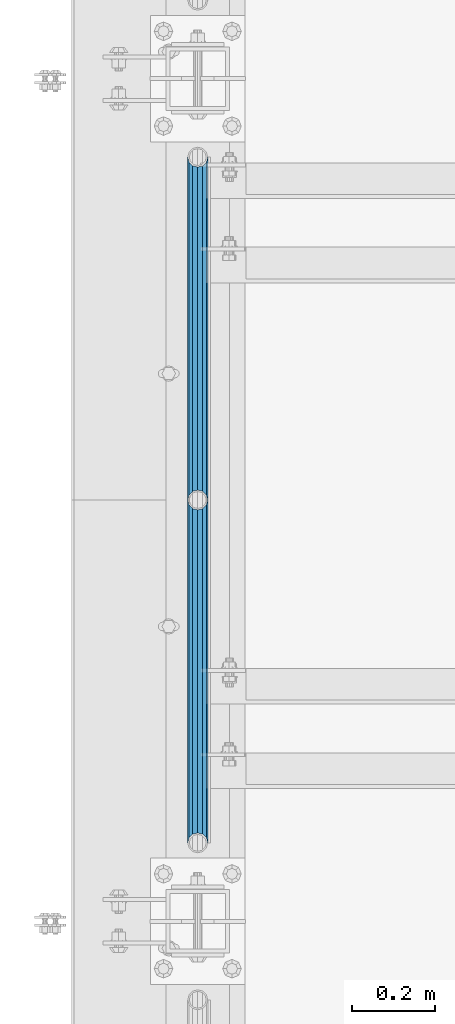
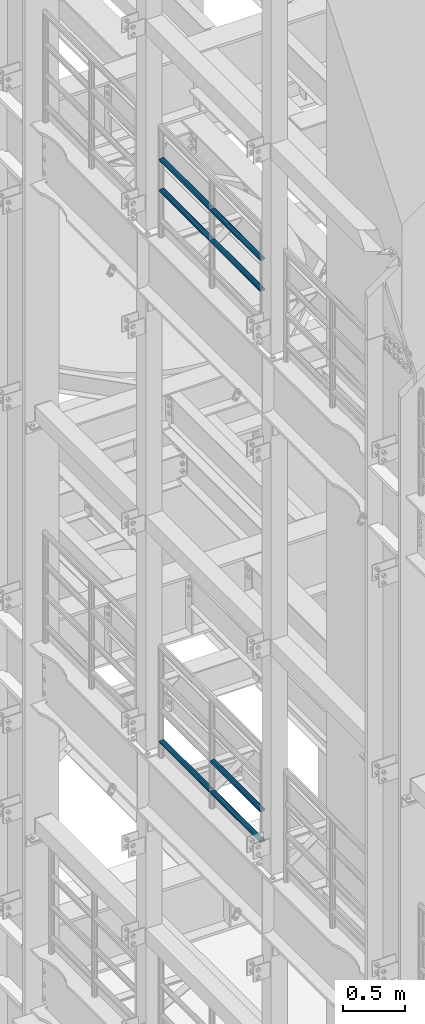
# One storey, part 1252 of 1876: 7 beams, 2 elements without a shape of their own.
"""IFC2X3 building model written with IfcOpenShell, lengths in millimetres."""

from ifc_helpers import new_model, si_unit, frame, origin_with_axes, place, context, subcontext, project, spatial, faceted_brep, material, type_object, element, aggregate, save


model = new_model("IFC2X3")

# Units and contexts
model_context = context("Model", 3, precision=1e-05, world=origin_with_axes())
body_context = subcontext(model_context, "Body", "Model", "MODEL_VIEW")
ifc_project = project(units=[si_unit("LENGTHUNIT", "METRE", prefix="MILLI"), si_unit("AREAUNIT", "SQUARE_METRE"), si_unit("VOLUMEUNIT", "CUBIC_METRE"), si_unit("MASSUNIT", "GRAM", prefix="KILO"), si_unit("TIMEUNIT", "SECOND"), si_unit("PLANEANGLEUNIT", "RADIAN"), si_unit("SOLIDANGLEUNIT", "STERADIAN"), si_unit("THERMODYNAMICTEMPERATUREUNIT", "DEGREE_CELSIUS"), si_unit("LUMINOUSINTENSITYUNIT", "LUMEN")], contexts=[model_context])

# Site, building, storey
site_placement = place(None, origin_with_axes())
site = spatial("IfcSite", under=ifc_project, at=site_placement, CompositionType="ELEMENT")
building_placement = place(site_placement, origin_with_axes())
building = spatial("IfcBuilding", under=site, at=building_placement, Name="Undefined", CompositionType="ELEMENT")
storey_placement = place(building_placement, origin_with_axes())
storey = spatial("IfcBuildingStorey", under=building, at=storey_placement, Name="Undefined", CompositionType="ELEMENT", Elevation=0.0)

# Assembly, beams
assembly_1_placement = place(storey_placement, origin_with_axes())
assembly_1 = element("IfcElementAssembly", 1, at=assembly_1_placement, inside=storey, Name="RAIL", AssemblyPlace="NOTDEFINED", PredefinedType="RIGID_FRAME")
ifc_material = material()
beam_type = type_object("IfcBeamType", Name="PIPE1-1/2SCH40", PredefinedType="NOTDEFINED")
beam_1_placement = place(assembly_1_placement, frame((-1.81898940354586e-12, 3745.23, 13776.325), z_axis=(0.0, 0.0, -1.0), x_axis=(0.0, 1.0, 0.0)))
beam_1 = element("IfcBeam", 2, at=beam_1_placement, type_object=beam_type, material=ifc_material, Name="RAIL", ObjectType="PIPE1-1/2SCH40", context=body_context, shape_type="Brep", body=[
    faceted_brep([(0.0, 24.1299999999992, 0.0), (12.0650000000064, 20.8971929933177, -12.0649999999987), (12.0650000000064, 20.8971929933177, 12.0649999999987), (12.0650000000064, -20.8971929933177, 12.0649999999987), (12.0650000000064, -20.8971929933177, -12.0649999999987), (0.0, -24.1299999999992, 0.0), (20.8971929933249, -12.0650000000005, 20.8971929933177), (20.8971929933249, -12.0650000000005, 15.8661214311796), (15.2545715621445, -17.7076214311801, 10.2235000000001), (12.5151929933249, -20.4470000000001, 0.0), (15.2545715621445, -17.7076214311801, -10.2235000000001), (20.8971929933249, -12.0650000000005, -15.8661214311796), (20.8971929933249, -12.0650000000005, -20.8971929933177), (24.1300000000063, 0.0, -20.4470000000001), (24.1300000000063, 0.0, -24.130000000001), (21.3906214311868, -10.2235000000001, -17.7076214311819), (21.3906214311868, 10.2235000000001, -17.7076214311819), (20.8971929933249, 12.0650000000005, -15.8661214311796), (20.8971929933249, 12.0650000000005, -20.8971929933177), (15.2545715621445, 17.7076214311801, -10.2235000000001), (12.5151929933249, 20.4470000000001, 0.0), (15.2545715621445, 17.7076214311801, 10.2235000000001), (20.8971929933249, 12.0650000000005, 15.8661214311796), (20.8971929933249, 12.0650000000005, 20.8971929933177), (21.3906214311868, 10.2235000000001, 17.7076214311819), (24.1300000000064, 0.0, 20.4470000000001), (24.1300000000064, 0.0, 24.130000000001), (21.3906214311868, -10.2235000000001, 17.7076214311819), (826.77, 24.1300000000001, 0.0), (814.705, 20.8971929933186, -12.0649999999987), (805.872807006681, 12.0649999999996, -20.8971929933177), (826.77, -24.1300000000001, 0.0), (814.705, -20.8971929933186, -12.0649999999987), (814.705, -20.8971929933186, 12.0649999999987), (805.872807006681, -12.0649999999996, 20.8971929933177), (805.872807006681, -12.0649999999996, -20.8971929933177), (802.640000000001, 0.0, -24.130000000001), (805.379378568819, 10.2235000000001, -17.7076214311819), (802.640000000001, 0.0, -20.4470000000001), (805.872807006683, 12.0649999999996, -15.8661214311796), (805.872807006683, -12.0649999999996, -15.8661214311796), (805.379378568819, -10.2235000000001, -17.7076214311819), (811.515428437862, -17.7076214311801, -10.2235000000001), (814.254807006682, -20.4470000000001, 0.0), (811.515428437862, -17.7076214311801, 10.2235000000001), (805.872807006683, -12.0649999999996, 15.8661214311796), (805.379378568819, -10.2235000000001, 17.7076214311819), (802.640000000001, 0.0, 20.4470000000001), (802.640000000001, 0.0, 24.130000000001), (805.872807006681, 12.0649999999996, 20.8971929933177), (814.705, 20.8971929933186, 12.0649999999987), (805.872807006683, 12.0649999999996, 15.8661214311796), (811.515428437862, 17.7076214311801, 10.2235000000001), (814.254807006682, 20.4470000000001, 0.0), (811.515428437862, 17.7076214311801, -10.2235000000001), (805.379378568819, 10.2235000000001, 17.7076214311819)], [[[0, 1, 2]], [[3, 4, 5]], [[6, 7, 8, 9, 10, 11, 12, 4, 3]], [[13, 14, 12, 11, 15]], [[16, 17, 18, 14, 13]], [[2, 1, 18, 17, 19, 20, 21, 22, 23]], [[23, 22, 24, 25, 26]], [[26, 25, 27, 7, 6]], [[1, 0, 28, 29]], [[18, 1, 29, 30]], [[31, 32, 33]], [[6, 3, 33, 34]], [[3, 5, 31, 33]], [[5, 4, 32, 31]], [[4, 12, 35, 32]], [[12, 14, 36, 35]], [[14, 18, 30, 36]], [[37, 38, 36, 30, 39]], [[40, 35, 36, 38, 41]], [[33, 32, 35, 40, 42, 43, 44, 45, 34]], [[34, 45, 46, 47, 48]], [[26, 6, 34, 48]], [[2, 23, 49, 50]], [[23, 26, 48, 49]], [[0, 2, 50, 28]], [[28, 50, 29]], [[49, 51, 52, 53, 54, 39, 30, 29, 50]], [[48, 47, 55, 51, 49]], [[25, 24, 55, 47]], [[55, 24, 22, 21, 52, 51]], [[21, 20, 53, 52]], [[20, 19, 54, 53]], [[19, 17, 16, 37, 39, 54]], [[16, 13, 38, 37]], [[13, 15, 41, 38]], [[41, 15, 11, 10, 42, 40]], [[10, 9, 43, 42]], [[9, 8, 44, 43]], [[8, 7, 27, 46, 45, 44]], [[27, 25, 47, 46]]]),
])
beam_2_placement = place(assembly_1_placement, frame((-1.81898940354586e-12, 4572.0, 13776.325), z_axis=(0.0, 0.0, -1.0), x_axis=(0.0, 1.0, 0.0)))
beam_2 = element("IfcBeam", 3, at=beam_2_placement, type_object=beam_type, material=ifc_material, Name="RAIL", ObjectType="PIPE1-1/2SCH40", context=body_context, shape_type="Brep", body=[
    faceted_brep([(0.0, 24.1299999999992, 0.0), (12.0650000000064, 20.8971929933177, -12.0649999999987), (12.0650000000064, 20.8971929933177, 12.0649999999987), (12.0650000000064, -20.8971929933177, 12.0649999999987), (12.0650000000064, -20.8971929933177, -12.0649999999987), (0.0, -24.1299999999992, 0.0), (20.8971929933249, -12.0650000000005, 20.8971929933177), (20.8971929933249, -12.0650000000005, 15.8661214311796), (15.2545715621445, -17.7076214311801, 10.2235000000001), (12.5151929933249, -20.4470000000001, 0.0), (15.2545715621445, -17.7076214311801, -10.2235000000001), (20.8971929933249, -12.0650000000005, -15.8661214311796), (20.8971929933249, -12.0650000000005, -20.8971929933177), (24.1300000000063, 0.0, -20.4470000000001), (24.1300000000063, 0.0, -24.130000000001), (21.3906214311868, -10.2235000000001, -17.7076214311819), (21.3906214311868, 10.2235000000001, -17.7076214311819), (20.8971929933249, 12.0650000000005, -15.8661214311796), (20.8971929933249, 12.0650000000005, -20.8971929933177), (15.2545715621445, 17.7076214311801, -10.2235000000001), (12.5151929933249, 20.4470000000001, 0.0), (15.2545715621445, 17.7076214311801, 10.2235000000001), (20.8971929933249, 12.0650000000005, 15.8661214311796), (20.8971929933249, 12.0650000000005, 20.8971929933177), (21.3906214311868, 10.2235000000001, 17.7076214311819), (24.1300000000064, 0.0, 20.4470000000001), (24.1300000000064, 0.0, 24.130000000001), (21.3906214311868, -10.2235000000001, 17.7076214311819), (826.77, 24.1300000000001, 0.0), (814.705, 20.8971929933186, -12.0649999999987), (805.872807006681, 12.0649999999996, -20.8971929933177), (826.77, -24.1300000000001, 0.0), (814.705, -20.8971929933186, -12.0649999999987), (814.705, -20.8971929933186, 12.0649999999987), (805.872807006681, -12.0649999999996, 20.8971929933177), (805.872807006681, -12.0649999999996, -20.8971929933177), (802.640000000001, 0.0, -24.130000000001), (805.379378568819, 10.2235000000001, -17.7076214311819), (802.640000000001, 0.0, -20.4470000000001), (805.872807006683, 12.0649999999996, -15.8661214311796), (805.872807006683, -12.0649999999996, -15.8661214311796), (805.379378568819, -10.2235000000001, -17.7076214311819), (811.515428437862, -17.7076214311801, -10.2235000000001), (814.254807006682, -20.4470000000001, 0.0), (811.515428437862, -17.7076214311801, 10.2235000000001), (805.872807006683, -12.0649999999996, 15.8661214311796), (805.379378568819, -10.2235000000001, 17.7076214311819), (802.640000000001, 0.0, 20.4470000000001), (802.640000000001, 0.0, 24.130000000001), (805.872807006681, 12.0649999999996, 20.8971929933177), (814.705, 20.8971929933186, 12.0649999999987), (805.872807006683, 12.0649999999996, 15.8661214311796), (811.515428437862, 17.7076214311801, 10.2235000000001), (814.254807006682, 20.4470000000001, 0.0), (811.515428437862, 17.7076214311801, -10.2235000000001), (805.379378568819, 10.2235000000001, 17.7076214311819)], [[[0, 1, 2]], [[3, 4, 5]], [[6, 7, 8, 9, 10, 11, 12, 4, 3]], [[13, 14, 12, 11, 15]], [[16, 17, 18, 14, 13]], [[2, 1, 18, 17, 19, 20, 21, 22, 23]], [[23, 22, 24, 25, 26]], [[26, 25, 27, 7, 6]], [[1, 0, 28, 29]], [[18, 1, 29, 30]], [[31, 32, 33]], [[6, 3, 33, 34]], [[3, 5, 31, 33]], [[5, 4, 32, 31]], [[4, 12, 35, 32]], [[12, 14, 36, 35]], [[14, 18, 30, 36]], [[37, 38, 36, 30, 39]], [[40, 35, 36, 38, 41]], [[33, 32, 35, 40, 42, 43, 44, 45, 34]], [[34, 45, 46, 47, 48]], [[26, 6, 34, 48]], [[2, 23, 49, 50]], [[23, 26, 48, 49]], [[0, 2, 50, 28]], [[28, 50, 29]], [[49, 51, 52, 53, 54, 39, 30, 29, 50]], [[48, 47, 55, 51, 49]], [[25, 24, 55, 47]], [[55, 24, 22, 21, 52, 51]], [[21, 20, 53, 52]], [[20, 19, 54, 53]], [[19, 17, 16, 37, 39, 54]], [[16, 13, 38, 37]], [[13, 15, 41, 38]], [[41, 15, 11, 10, 42, 40]], [[10, 9, 43, 42]], [[9, 8, 44, 43]], [[8, 7, 27, 46, 45, 44]], [[27, 25, 47, 46]]]),
])
beam_3_placement = place(assembly_1_placement, frame((-1.81898940354586e-12, 3745.23, 14081.125), z_axis=(0.0, 0.0, -1.0), x_axis=(0.0, 1.0, 0.0)))
beam_3 = element("IfcBeam", 4, at=beam_3_placement, type_object=beam_type, material=ifc_material, Name="RAIL", ObjectType="PIPE1-1/2SCH40", context=body_context, shape_type="Brep", body=[
    faceted_brep([(0.0, 24.1299999999992, 0.0), (12.0650000000064, 20.8971929933177, -12.0649999999987), (12.0650000000064, 20.8971929933177, 12.0649999999987), (12.0650000000064, -20.8971929933177, 12.0649999999987), (12.0650000000064, -20.8971929933177, -12.0649999999987), (0.0, -24.1299999999992, 0.0), (20.8971929933249, -12.0650000000005, 20.8971929933177), (20.8971929933249, -12.0650000000005, 15.8661214311796), (15.2545715621445, -17.7076214311801, 10.2235000000001), (12.5151929933249, -20.4470000000001, 0.0), (15.2545715621445, -17.7076214311801, -10.2235000000001), (20.8971929933249, -12.0650000000005, -15.8661214311796), (20.8971929933249, -12.0650000000005, -20.8971929933177), (24.1300000000063, 0.0, -20.4470000000001), (24.1300000000063, 0.0, -24.130000000001), (21.3906214311868, -10.2235000000001, -17.7076214311819), (21.3906214311868, 10.2235000000001, -17.7076214311819), (20.8971929933249, 12.0650000000005, -15.8661214311796), (20.8971929933249, 12.0650000000005, -20.8971929933177), (15.2545715621445, 17.7076214311801, -10.2235000000001), (12.5151929933249, 20.4470000000001, 0.0), (15.2545715621445, 17.7076214311801, 10.2235000000001), (20.8971929933249, 12.0650000000005, 15.8661214311796), (20.8971929933249, 12.0650000000005, 20.8971929933177), (21.3906214311868, 10.2235000000001, 17.7076214311819), (24.1300000000064, 0.0, 20.4470000000001), (24.1300000000064, 0.0, 24.130000000001), (21.3906214311868, -10.2235000000001, 17.7076214311819), (826.77, 24.1300000000001, 0.0), (814.705, 20.8971929933186, -12.0649999999987), (805.872807006681, 12.0649999999996, -20.8971929933177), (826.77, -24.1300000000001, 0.0), (814.705, -20.8971929933186, -12.0649999999987), (814.705, -20.8971929933186, 12.0649999999987), (805.872807006681, -12.0649999999996, 20.8971929933177), (805.872807006681, -12.0649999999996, -20.8971929933177), (802.640000000001, 0.0, -24.130000000001), (805.379378568819, 10.2235000000001, -17.7076214311819), (802.640000000001, 0.0, -20.4470000000001), (805.872807006683, 12.0649999999996, -15.8661214311796), (805.872807006683, -12.0649999999996, -15.8661214311796), (805.379378568819, -10.2235000000001, -17.7076214311819), (811.515428437862, -17.7076214311801, -10.2235000000001), (814.254807006682, -20.4470000000001, 0.0), (811.515428437862, -17.7076214311801, 10.2235000000001), (805.872807006683, -12.0649999999996, 15.8661214311796), (805.379378568819, -10.2235000000001, 17.7076214311819), (802.640000000001, 0.0, 20.4470000000001), (802.640000000001, 0.0, 24.130000000001), (805.872807006681, 12.0649999999996, 20.8971929933177), (814.705, 20.8971929933186, 12.0649999999987), (805.872807006683, 12.0649999999996, 15.8661214311796), (811.515428437862, 17.7076214311801, 10.2235000000001), (814.254807006682, 20.4470000000001, 0.0), (811.515428437862, 17.7076214311801, -10.2235000000001), (805.379378568819, 10.2235000000001, 17.7076214311819)], [[[0, 1, 2]], [[3, 4, 5]], [[6, 7, 8, 9, 10, 11, 12, 4, 3]], [[13, 14, 12, 11, 15]], [[16, 17, 18, 14, 13]], [[2, 1, 18, 17, 19, 20, 21, 22, 23]], [[23, 22, 24, 25, 26]], [[26, 25, 27, 7, 6]], [[1, 0, 28, 29]], [[18, 1, 29, 30]], [[31, 32, 33]], [[6, 3, 33, 34]], [[3, 5, 31, 33]], [[5, 4, 32, 31]], [[4, 12, 35, 32]], [[12, 14, 36, 35]], [[14, 18, 30, 36]], [[37, 38, 36, 30, 39]], [[40, 35, 36, 38, 41]], [[33, 32, 35, 40, 42, 43, 44, 45, 34]], [[34, 45, 46, 47, 48]], [[26, 6, 34, 48]], [[2, 23, 49, 50]], [[23, 26, 48, 49]], [[0, 2, 50, 28]], [[28, 50, 29]], [[49, 51, 52, 53, 54, 39, 30, 29, 50]], [[48, 47, 55, 51, 49]], [[25, 24, 55, 47]], [[55, 24, 22, 21, 52, 51]], [[21, 20, 53, 52]], [[20, 19, 54, 53]], [[19, 17, 16, 37, 39, 54]], [[16, 13, 38, 37]], [[13, 15, 41, 38]], [[41, 15, 11, 10, 42, 40]], [[10, 9, 43, 42]], [[9, 8, 44, 43]], [[8, 7, 27, 46, 45, 44]], [[27, 25, 47, 46]]]),
])
beam_4_placement = place(assembly_1_placement, frame((-1.81898940354586e-12, 4572.0, 14081.125), z_axis=(0.0, 0.0, -1.0), x_axis=(0.0, 1.0, 0.0)))
beam_4 = element("IfcBeam", 5, at=beam_4_placement, type_object=beam_type, material=ifc_material, Name="RAIL", ObjectType="PIPE1-1/2SCH40", context=body_context, shape_type="Brep", body=[
    faceted_brep([(0.0, 24.1299999999992, 0.0), (12.0650000000064, 20.8971929933177, -12.0649999999987), (12.0650000000064, 20.8971929933177, 12.0649999999987), (12.0650000000064, -20.8971929933177, 12.0649999999987), (12.0650000000064, -20.8971929933177, -12.0649999999987), (0.0, -24.1299999999992, 0.0), (20.8971929933249, -12.0650000000005, 20.8971929933177), (20.8971929933249, -12.0650000000005, 15.8661214311796), (15.2545715621445, -17.7076214311801, 10.2235000000001), (12.5151929933249, -20.4470000000001, 0.0), (15.2545715621445, -17.7076214311801, -10.2235000000001), (20.8971929933249, -12.0650000000005, -15.8661214311796), (20.8971929933249, -12.0650000000005, -20.8971929933177), (24.1300000000063, 0.0, -20.4470000000001), (24.1300000000063, 0.0, -24.130000000001), (21.3906214311868, -10.2235000000001, -17.7076214311819), (21.3906214311868, 10.2235000000001, -17.7076214311819), (20.8971929933249, 12.0650000000005, -15.8661214311796), (20.8971929933249, 12.0650000000005, -20.8971929933177), (15.2545715621445, 17.7076214311801, -10.2235000000001), (12.5151929933249, 20.4470000000001, 0.0), (15.2545715621445, 17.7076214311801, 10.2235000000001), (20.8971929933249, 12.0650000000005, 15.8661214311796), (20.8971929933249, 12.0650000000005, 20.8971929933177), (21.3906214311868, 10.2235000000001, 17.7076214311819), (24.1300000000064, 0.0, 20.4470000000001), (24.1300000000064, 0.0, 24.130000000001), (21.3906214311868, -10.2235000000001, 17.7076214311819), (826.77, 24.1300000000001, 0.0), (814.705, 20.8971929933186, -12.0649999999987), (805.872807006681, 12.0649999999996, -20.8971929933177), (826.77, -24.1300000000001, 0.0), (814.705, -20.8971929933186, -12.0649999999987), (814.705, -20.8971929933186, 12.0649999999987), (805.872807006681, -12.0649999999996, 20.8971929933177), (805.872807006681, -12.0649999999996, -20.8971929933177), (802.640000000001, 0.0, -24.130000000001), (805.379378568819, 10.2235000000001, -17.7076214311819), (802.640000000001, 0.0, -20.4470000000001), (805.872807006683, 12.0649999999996, -15.8661214311796), (805.872807006683, -12.0649999999996, -15.8661214311796), (805.379378568819, -10.2235000000001, -17.7076214311819), (811.515428437862, -17.7076214311801, -10.2235000000001), (814.254807006682, -20.4470000000001, 0.0), (811.515428437862, -17.7076214311801, 10.2235000000001), (805.872807006683, -12.0649999999996, 15.8661214311796), (805.379378568819, -10.2235000000001, 17.7076214311819), (802.640000000001, 0.0, 20.4470000000001), (802.640000000001, 0.0, 24.130000000001), (805.872807006681, 12.0649999999996, 20.8971929933177), (814.705, 20.8971929933186, 12.0649999999987), (805.872807006683, 12.0649999999996, 15.8661214311796), (811.515428437862, 17.7076214311801, 10.2235000000001), (814.254807006682, 20.4470000000001, 0.0), (811.515428437862, 17.7076214311801, -10.2235000000001), (805.379378568819, 10.2235000000001, 17.7076214311819)], [[[0, 1, 2]], [[3, 4, 5]], [[6, 7, 8, 9, 10, 11, 12, 4, 3]], [[13, 14, 12, 11, 15]], [[16, 17, 18, 14, 13]], [[2, 1, 18, 17, 19, 20, 21, 22, 23]], [[23, 22, 24, 25, 26]], [[26, 25, 27, 7, 6]], [[1, 0, 28, 29]], [[18, 1, 29, 30]], [[31, 32, 33]], [[6, 3, 33, 34]], [[3, 5, 31, 33]], [[5, 4, 32, 31]], [[4, 12, 35, 32]], [[12, 14, 36, 35]], [[14, 18, 30, 36]], [[37, 38, 36, 30, 39]], [[40, 35, 36, 38, 41]], [[33, 32, 35, 40, 42, 43, 44, 45, 34]], [[34, 45, 46, 47, 48]], [[26, 6, 34, 48]], [[2, 23, 49, 50]], [[23, 26, 48, 49]], [[0, 2, 50, 28]], [[28, 50, 29]], [[49, 51, 52, 53, 54, 39, 30, 29, 50]], [[48, 47, 55, 51, 49]], [[25, 24, 55, 47]], [[55, 24, 22, 21, 52, 51]], [[21, 20, 53, 52]], [[20, 19, 54, 53]], [[19, 17, 16, 37, 39, 54]], [[16, 13, 38, 37]], [[13, 15, 41, 38]], [[41, 15, 11, 10, 42, 40]], [[10, 9, 43, 42]], [[9, 8, 44, 43]], [[8, 7, 27, 46, 45, 44]], [[27, 25, 47, 46]]]),
])
aggregate(assembly_1, [beam_1, beam_2, beam_3, beam_4])

assembly_2_placement = place(storey_placement, origin_with_axes())
assembly_2 = element("IfcElementAssembly", 6, at=assembly_2_placement, inside=storey, Name="RAIL", AssemblyPlace="NOTDEFINED", PredefinedType="RIGID_FRAME")
beam_5_placement = place(assembly_2_placement, frame((-1.81898940354586e-12, 4572.0, 8315.325), z_axis=(0.0, 0.0, 1.0), x_axis=(0.0, -1.0, 0.0)))
beam_5 = element("IfcBeam", 7, at=beam_5_placement, type_object=beam_type, material=ifc_material, Name="RAIL", ObjectType="PIPE1-1/2SCH40", context=body_context, shape_type="Brep", body=[
    faceted_brep([(805.872807006681, -12.0649999999996, 20.8971929933177), (805.872807006683, -12.0649999999996, 15.8661214311796), (805.379378568819, -10.2235000000001, 17.7076214311819), (802.640000000001, 0.0, 20.4470000000001), (802.640000000001, 0.0, 24.130000000001), (805.379378568819, 10.2235000000001, 17.7076214311819), (805.872807006683, 12.0649999999996, 15.8661214311796), (805.872807006681, 12.0649999999996, 20.8971929933177), (826.77, 24.1300000000001, 0.0), (814.705, 20.8971929933186, 12.0649999999987), (814.705, 20.8971929933186, -12.0649999999987), (811.515428437862, 17.7076214311801, 10.2235000000001), (814.254807006682, 20.4470000000001, 0.0), (811.515428437862, 17.7076214311801, -10.2235000000001), (805.872807006683, 12.0649999999996, -15.8661214311796), (805.872807006681, 12.0649999999996, -20.8971929933177), (805.379378568819, 10.2235000000001, -17.7076214311819), (802.640000000001, 0.0, -20.4470000000001), (802.640000000001, 0.0, -24.130000000001), (805.872807006683, -12.0649999999996, -15.8661214311796), (805.872807006681, -12.0649999999996, -20.8971929933177), (805.379378568819, -10.2235000000001, -17.7076214311819), (826.77, -24.1300000000001, 0.0), (814.705, -20.8971929933186, -12.0649999999987), (814.705, -20.8971929933186, 12.0649999999987), (811.515428437862, -17.7076214311801, -10.2235000000001), (814.254807006682, -20.4470000000001, 0.0), (811.515428437862, -17.7076214311801, 10.2235000000001), (12.0650000000064, -20.8971929933177, -12.0649999999987), (20.8971929933249, -12.0650000000005, -20.8971929933177), (0.0, 24.1299999999992, 0.0), (12.0650000000064, 20.8971929933177, -12.0649999999987), (12.0650000000064, 20.8971929933177, 12.0649999999987), (20.8971929933249, 12.0650000000005, 20.8971929933177), (24.1300000000064, 0.0, 24.130000000001), (20.8971929933249, 12.0650000000005, -20.8971929933177), (24.1300000000063, 0.0, -24.130000000001), (24.1300000000063, 0.0, -20.4470000000001), (20.8971929933249, -12.0650000000005, -15.8661214311796), (21.3906214311868, -10.2235000000001, -17.7076214311819), (21.3906214311868, 10.2235000000001, -17.7076214311819), (20.8971929933249, 12.0650000000005, -15.8661214311796), (15.2545715621445, 17.7076214311801, -10.2235000000001), (12.5151929933249, 20.4470000000001, 0.0), (15.2545715621445, 17.7076214311801, 10.2235000000001), (20.8971929933249, 12.0650000000005, 15.8661214311796), (21.3906214311868, 10.2235000000001, 17.7076214311819), (24.1300000000064, 0.0, 20.4470000000001), (21.3906214311868, -10.2235000000001, 17.7076214311819), (20.8971929933249, -12.0650000000005, 15.8661214311796), (20.8971929933249, -12.0650000000005, 20.8971929933177), (12.0650000000064, -20.8971929933177, 12.0649999999987), (0.0, -24.1299999999992, 0.0), (15.2545715621445, -17.7076214311801, 10.2235000000001), (12.5151929933249, -20.4470000000001, 0.0), (15.2545715621445, -17.7076214311801, -10.2235000000001)], [[[0, 1, 2, 3, 4]], [[4, 3, 5, 6, 7]], [[8, 9, 10]], [[7, 6, 11, 12, 13, 14, 15, 10, 9]], [[16, 17, 18, 15, 14]], [[19, 20, 18, 17, 21]], [[22, 23, 24]], [[24, 23, 20, 19, 25, 26, 27, 1, 0]], [[28, 29, 20, 23]], [[30, 31, 32]], [[33, 34, 4, 7]], [[32, 33, 7, 9]], [[30, 32, 9, 8]], [[31, 30, 8, 10]], [[35, 31, 10, 15]], [[36, 35, 15, 18]], [[29, 36, 18, 20]], [[37, 36, 29, 38, 39]], [[40, 41, 35, 36, 37]], [[32, 31, 35, 41, 42, 43, 44, 45, 33]], [[33, 45, 46, 47, 34]], [[34, 47, 48, 49, 50]], [[34, 50, 0, 4]], [[50, 51, 24, 0]], [[51, 52, 22, 24]], [[52, 28, 23, 22]], [[51, 28, 52]], [[50, 49, 53, 54, 55, 38, 29, 28, 51]], [[55, 54, 26, 25]], [[21, 39, 38, 55, 25, 19]], [[37, 39, 21, 17]], [[40, 37, 17, 16]], [[42, 41, 40, 16, 14, 13]], [[43, 42, 13, 12]], [[44, 43, 12, 11]], [[5, 46, 45, 44, 11, 6]], [[47, 46, 5, 3]], [[48, 47, 3, 2]], [[53, 49, 48, 2, 1, 27]], [[54, 53, 27, 26]]]),
])
beam_6_placement = place(assembly_2_placement, frame((-1.81898940354586e-12, 5398.77, 8315.325), z_axis=(0.0, 0.0, 1.0), x_axis=(0.0, -1.0, 0.0)))
beam_6 = element("IfcBeam", 8, at=beam_6_placement, type_object=beam_type, material=ifc_material, Name="RAIL", ObjectType="PIPE1-1/2SCH40", context=body_context, shape_type="Brep", body=[
    faceted_brep([(805.872807006681, -12.0649999999996, 20.8971929933177), (805.872807006683, -12.0649999999996, 15.8661214311796), (805.379378568819, -10.2235000000001, 17.7076214311819), (802.640000000001, 0.0, 20.4470000000001), (802.640000000001, 0.0, 24.130000000001), (805.379378568819, 10.2235000000001, 17.7076214311819), (805.872807006683, 12.0649999999996, 15.8661214311796), (805.872807006681, 12.0649999999996, 20.8971929933177), (826.77, 24.1300000000001, 0.0), (814.705, 20.8971929933186, 12.0649999999987), (814.705, 20.8971929933186, -12.0649999999987), (811.515428437862, 17.7076214311801, 10.2235000000001), (814.254807006682, 20.4470000000001, 0.0), (811.515428437862, 17.7076214311801, -10.2235000000001), (805.872807006683, 12.0649999999996, -15.8661214311796), (805.872807006681, 12.0649999999996, -20.8971929933177), (805.379378568819, 10.2235000000001, -17.7076214311819), (802.640000000001, 0.0, -20.4470000000001), (802.640000000001, 0.0, -24.130000000001), (805.872807006683, -12.0649999999996, -15.8661214311796), (805.872807006681, -12.0649999999996, -20.8971929933177), (805.379378568819, -10.2235000000001, -17.7076214311819), (826.77, -24.1300000000001, 0.0), (814.705, -20.8971929933186, -12.0649999999987), (814.705, -20.8971929933186, 12.0649999999987), (811.515428437862, -17.7076214311801, -10.2235000000001), (814.254807006682, -20.4470000000001, 0.0), (811.515428437862, -17.7076214311801, 10.2235000000001), (12.0650000000064, -20.8971929933177, -12.0649999999987), (20.8971929933249, -12.0650000000005, -20.8971929933177), (0.0, 24.1299999999992, 0.0), (12.0650000000064, 20.8971929933177, -12.0649999999987), (12.0650000000064, 20.8971929933177, 12.0649999999987), (20.8971929933249, 12.0650000000005, 20.8971929933177), (24.1300000000064, 0.0, 24.130000000001), (20.8971929933249, 12.0650000000005, -20.8971929933177), (24.1300000000063, 0.0, -24.130000000001), (24.1300000000063, 0.0, -20.4470000000001), (20.8971929933249, -12.0650000000005, -15.8661214311796), (21.3906214311868, -10.2235000000001, -17.7076214311819), (21.3906214311868, 10.2235000000001, -17.7076214311819), (20.8971929933249, 12.0650000000005, -15.8661214311796), (15.2545715621445, 17.7076214311801, -10.2235000000001), (12.5151929933249, 20.4470000000001, 0.0), (15.2545715621445, 17.7076214311801, 10.2235000000001), (20.8971929933249, 12.0650000000005, 15.8661214311796), (21.3906214311868, 10.2235000000001, 17.7076214311819), (24.1300000000064, 0.0, 20.4470000000001), (21.3906214311868, -10.2235000000001, 17.7076214311819), (20.8971929933249, -12.0650000000005, 15.8661214311796), (20.8971929933249, -12.0650000000005, 20.8971929933177), (12.0650000000064, -20.8971929933177, 12.0649999999987), (0.0, -24.1299999999992, 0.0), (15.2545715621445, -17.7076214311801, 10.2235000000001), (12.5151929933249, -20.4470000000001, 0.0), (15.2545715621445, -17.7076214311801, -10.2235000000001)], [[[0, 1, 2, 3, 4]], [[4, 3, 5, 6, 7]], [[8, 9, 10]], [[7, 6, 11, 12, 13, 14, 15, 10, 9]], [[16, 17, 18, 15, 14]], [[19, 20, 18, 17, 21]], [[22, 23, 24]], [[24, 23, 20, 19, 25, 26, 27, 1, 0]], [[28, 29, 20, 23]], [[30, 31, 32]], [[33, 34, 4, 7]], [[32, 33, 7, 9]], [[30, 32, 9, 8]], [[31, 30, 8, 10]], [[35, 31, 10, 15]], [[36, 35, 15, 18]], [[29, 36, 18, 20]], [[37, 36, 29, 38, 39]], [[40, 41, 35, 36, 37]], [[32, 31, 35, 41, 42, 43, 44, 45, 33]], [[33, 45, 46, 47, 34]], [[34, 47, 48, 49, 50]], [[34, 50, 0, 4]], [[50, 51, 24, 0]], [[51, 52, 22, 24]], [[52, 28, 23, 22]], [[51, 28, 52]], [[50, 49, 53, 54, 55, 38, 29, 28, 51]], [[55, 54, 26, 25]], [[21, 39, 38, 55, 25, 19]], [[37, 39, 21, 17]], [[40, 37, 17, 16]], [[42, 41, 40, 16, 14, 13]], [[43, 42, 13, 12]], [[44, 43, 12, 11]], [[5, 46, 45, 44, 11, 6]], [[47, 46, 5, 3]], [[48, 47, 3, 2]], [[53, 49, 48, 2, 1, 27]], [[54, 53, 27, 26]]]),
])
beam_7_placement = place(assembly_2_placement, frame((-1.81898940354586e-12, 3745.23, 8620.125), z_axis=(0.0, 0.0, -1.0), x_axis=(0.0, 1.0, 0.0)))
beam_7 = element("IfcBeam", 9, at=beam_7_placement, type_object=beam_type, material=ifc_material, Name="RAIL", ObjectType="PIPE1-1/2SCH40", context=body_context, shape_type="Brep", body=[
    faceted_brep([(0.0, 24.1299999999992, 0.0), (12.0650000000064, 20.8971929933177, -12.0649999999987), (12.0650000000064, 20.8971929933177, 12.0649999999987), (12.0650000000064, -20.8971929933177, 12.0649999999987), (12.0650000000064, -20.8971929933177, -12.0649999999987), (0.0, -24.1299999999992, 0.0), (20.8971929933249, -12.0650000000005, 20.8971929933177), (20.8971929933249, -12.0650000000005, 15.8661214311796), (15.2545715621445, -17.7076214311801, 10.2235000000001), (12.5151929933249, -20.4470000000001, 0.0), (15.2545715621445, -17.7076214311801, -10.2235000000001), (20.8971929933249, -12.0650000000005, -15.8661214311796), (20.8971929933249, -12.0650000000005, -20.8971929933177), (24.1300000000063, 0.0, -20.4470000000001), (24.1300000000063, 0.0, -24.130000000001), (21.3906214311868, -10.2235000000001, -17.7076214311819), (21.3906214311868, 10.2235000000001, -17.7076214311819), (20.8971929933249, 12.0650000000005, -15.8661214311796), (20.8971929933249, 12.0650000000005, -20.8971929933177), (15.2545715621445, 17.7076214311801, -10.2235000000001), (12.5151929933249, 20.4470000000001, 0.0), (15.2545715621445, 17.7076214311801, 10.2235000000001), (20.8971929933249, 12.0650000000005, 15.8661214311796), (20.8971929933249, 12.0650000000005, 20.8971929933177), (21.3906214311868, 10.2235000000001, 17.7076214311819), (24.1300000000064, 0.0, 20.4470000000001), (24.1300000000064, 0.0, 24.130000000001), (21.3906214311868, -10.2235000000001, 17.7076214311819), (826.77, 24.1300000000001, 0.0), (814.705, 20.8971929933186, -12.0649999999987), (805.872807006681, 12.0649999999996, -20.8971929933177), (826.77, -24.1300000000001, 0.0), (814.705, -20.8971929933186, -12.0649999999987), (814.705, -20.8971929933186, 12.0649999999987), (805.872807006681, -12.0649999999996, 20.8971929933177), (805.872807006681, -12.0649999999996, -20.8971929933177), (802.640000000001, 0.0, -24.130000000001), (805.379378568819, 10.2235000000001, -17.7076214311819), (802.640000000001, 0.0, -20.4470000000001), (805.872807006683, 12.0649999999996, -15.8661214311796), (805.872807006683, -12.0649999999996, -15.8661214311796), (805.379378568819, -10.2235000000001, -17.7076214311819), (811.515428437862, -17.7076214311801, -10.2235000000001), (814.254807006682, -20.4470000000001, 0.0), (811.515428437862, -17.7076214311801, 10.2235000000001), (805.872807006683, -12.0649999999996, 15.8661214311796), (805.379378568819, -10.2235000000001, 17.7076214311819), (802.640000000001, 0.0, 20.4470000000001), (802.640000000001, 0.0, 24.130000000001), (805.872807006681, 12.0649999999996, 20.8971929933177), (814.705, 20.8971929933186, 12.0649999999987), (805.872807006683, 12.0649999999996, 15.8661214311796), (811.515428437862, 17.7076214311801, 10.2235000000001), (814.254807006682, 20.4470000000001, 0.0), (811.515428437862, 17.7076214311801, -10.2235000000001), (805.379378568819, 10.2235000000001, 17.7076214311819)], [[[0, 1, 2]], [[3, 4, 5]], [[6, 7, 8, 9, 10, 11, 12, 4, 3]], [[13, 14, 12, 11, 15]], [[16, 17, 18, 14, 13]], [[2, 1, 18, 17, 19, 20, 21, 22, 23]], [[23, 22, 24, 25, 26]], [[26, 25, 27, 7, 6]], [[1, 0, 28, 29]], [[18, 1, 29, 30]], [[31, 32, 33]], [[6, 3, 33, 34]], [[3, 5, 31, 33]], [[5, 4, 32, 31]], [[4, 12, 35, 32]], [[12, 14, 36, 35]], [[14, 18, 30, 36]], [[37, 38, 36, 30, 39]], [[40, 35, 36, 38, 41]], [[33, 32, 35, 40, 42, 43, 44, 45, 34]], [[34, 45, 46, 47, 48]], [[26, 6, 34, 48]], [[2, 23, 49, 50]], [[23, 26, 48, 49]], [[0, 2, 50, 28]], [[28, 50, 29]], [[49, 51, 52, 53, 54, 39, 30, 29, 50]], [[48, 47, 55, 51, 49]], [[25, 24, 55, 47]], [[55, 24, 22, 21, 52, 51]], [[21, 20, 53, 52]], [[20, 19, 54, 53]], [[19, 17, 16, 37, 39, 54]], [[16, 13, 38, 37]], [[13, 15, 41, 38]], [[41, 15, 11, 10, 42, 40]], [[10, 9, 43, 42]], [[9, 8, 44, 43]], [[8, 7, 27, 46, 45, 44]], [[27, 25, 47, 46]]]),
])
aggregate(assembly_2, [beam_5, beam_6, beam_7])

save(model, "model.ifc")
